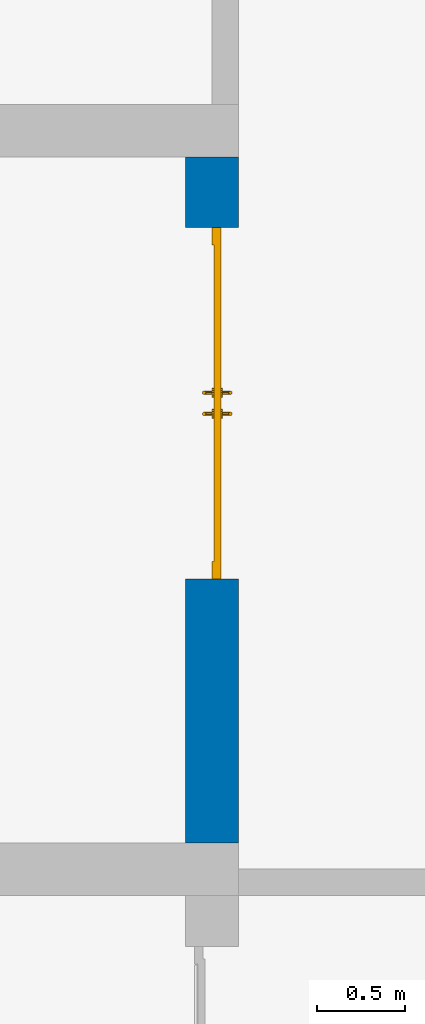
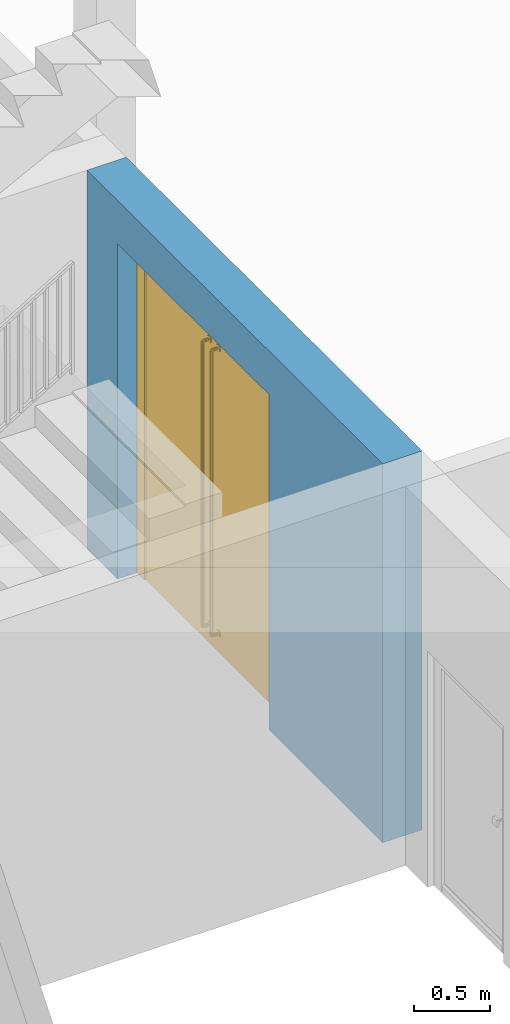
# One storey, part 18 of 23: 1 door, 1 wall, 1 opening.
"""IFC4 building model written with IfcOpenShell, lengths in metres."""

from ifc_helpers import new_model, entity, si_unit, converted_unit, derived_unit, direction, frame, origin_with_axes, place, context, subcontext, project, spatial, polygons, material, type_object, element, fill, save


model = new_model("IFC4")

# Units and contexts
model_context = context("Model", 3, precision=1e-05, world=origin_with_axes(), true_north=direction((0.0, 1.0)))
body_context = subcontext(model_context, "Body", "Model", "MODEL_VIEW")
ifc_project = project(units=[si_unit("LENGTHUNIT", "METRE"), si_unit("AREAUNIT", "SQUARE_METRE"), si_unit("VOLUMEUNIT", "CUBIC_METRE"), converted_unit("PLANEANGLEUNIT", "DEGREE", entity("IfcPlaneAngleMeasure", 0.0174532925199), si_unit("PLANEANGLEUNIT", "RADIAN"), dimensions=[0, 0, 0, 0, 0, 0, 0]), converted_unit("TIMEUNIT", "Year", entity("IfcTimeMeasure", 31556926.0), si_unit("TIMEUNIT", "SECOND"), dimensions=[0, 0, 1, 0, 0, 0, 0]), si_unit("MASSUNIT", "GRAM", prefix="KILO"), si_unit("THERMODYNAMICTEMPERATUREUNIT", "DEGREE_CELSIUS"), si_unit("LUMINOUSINTENSITYUNIT", "LUMEN"), si_unit("ENERGYUNIT", "JOULE", prefix="MEGA"), derived_unit("THERMALCONDUCTANCEUNIT", [(si_unit("POWERUNIT", "WATT"), 1), (si_unit("LENGTHUNIT", "METRE"), -1), (si_unit("THERMODYNAMICTEMPERATUREUNIT", "KELVIN"), -1)]), derived_unit("SPECIFICHEATCAPACITYUNIT", [(si_unit("ENERGYUNIT", "JOULE"), 1), (si_unit("MASSUNIT", "GRAM", prefix="KILO"), -1), (si_unit("THERMODYNAMICTEMPERATUREUNIT", "KELVIN"), -1)]), derived_unit("MASSDENSITYUNIT", [(si_unit("MASSUNIT", "GRAM", prefix="KILO"), 1), (si_unit("VOLUMEUNIT", "CUBIC_METRE"), -1)])], contexts=[model_context])

# Site, building, storey
site_placement = place(None, origin_with_axes())
site = spatial("IfcSite", under=ifc_project, at=site_placement, CompositionType="ELEMENT")
building_placement = place(site_placement, origin_with_axes())
building = spatial("IfcBuilding", under=site, at=building_placement, CompositionType="ELEMENT")
storey_placement = place(building_placement, origin_with_axes())
storey = spatial("IfcBuildingStorey", under=building, at=storey_placement, Name="0. Geschoss", CompositionType="ELEMENT", Elevation=0.0)

# Wall, opening, door
ifc_material = material()
wall_type = type_object("IfcWallType", Name="300", PredefinedType="NOTDEFINED")
wall_placement = place(storey_placement, frame((2.8378006196, -2.52881223104, 0.0), z_axis=(0.0, 0.0, 1.0), x_axis=(0.0, 1.0, 0.0)))
wall = element("IfcWall", 1, at=wall_placement, inside=storey, type_object=wall_type, material=ifc_material, Name="Wand-001", PredefinedType="NOTDEFINED", context=body_context, shape_type="Tessellation", body=[
    polygons([(1.5, 0.0, 2.7), (1.5, 0.3, 2.7), (3.5, 0.3, 2.7), (3.5, 0.0, 2.7), (1.5, 0.1, 0.0), (1.5, 0.3, 0.0), (1.5, 0.0, 0.0), (0.0, 0.3, 0.0), (0.0, 0.3, 3.05), (3.9, 0.3, 3.05), (3.9, 0.3, 0.0), (3.5, 0.3, 0.0), (3.5, 0.1, 0.0), (3.5, 0.0, 0.0), (3.9, 0.0, 3.05), (0.0, 0.0, 3.05), (0.0, 0.0, 0.0), (3.9, 0.0, 0.0)], [[[1, 2, 3, 4]], [[5, 6, 2, 1, 7]], [[2, 6, 8, 9, 10, 11, 12, 3]], [[4, 3, 12, 13, 14]], [[15, 16, 17, 7, 1, 4, 14, 18]], [[6, 5, 7, 17, 8]], [[9, 8, 17, 16]], [[15, 10, 9, 16]], [[15, 18, 11, 10]], [[13, 12, 11, 18, 14]]], closed=True),
])
opening_placement = place(wall_placement, frame((2.5, 0.0, 0.0), z_axis=(0.0, 0.0, 1.0), x_axis=(1.0, 0.0, 0.0)))
opening = element("IfcOpeningElement", 2, at=opening_placement, cuts=wall, context=body_context, identifier="Reference", shape_type="Tessellation", body=[
    polygons([(1.0, 0.1, 0.0), (1.0, 0.1, 2.7), (1.0, -0.001, 2.7), (1.0, -0.001, 0.0), (1.0, 0.301, 0.0), (1.0, 0.301, 2.7), (-1.0, 0.1, 2.7), (-1.0, -0.001, 2.7), (-1.0, 0.301, 2.7), (-1.0, -0.001, 0.0), (-1.0, 0.1, 0.0), (-1.0, 0.301, 0.0)], [[[1, 2, 3, 4]], [[2, 1, 5, 6]], [[7, 8, 3, 2, 6, 9]], [[8, 10, 4, 3]], [[1, 4, 10, 11, 12, 5]], [[6, 5, 12, 9]], [[7, 11, 10, 8]], [[11, 7, 9, 12]]], closed=True),
])
door_type = type_object("IfcDoorType", Name="Eingang 02 2-Fl 26", OperationType="DOUBLE_DOOR_SINGLE_SWING", PredefinedType="DOOR")
door_placement = place(opening_placement, frame((0.9, 0.0, 0.0), z_axis=(0.0, 0.0, 1.0), x_axis=(-1.0, 0.0, 0.0)))
door = element("IfcDoor", 3, at=door_placement, inside=storey, type_object=door_type, OverallHeight=2.7, OverallWidth=2.0, PredefinedType="DOOR", context=body_context, shape_type="Tessellation", body=[
    polygons([(-0.1, -0.15, 0.0), (-0.1, -0.15, 2.7), (-0.1, -0.14, 2.7), (-0.1, -0.14, 0.0), (0.0, -0.15, 0.0), (0.0, -0.15, 2.6), (0.7999, -0.15, 2.6), (0.8999, -0.15, 2.6), (1.8, -0.15, 2.6), (1.8, -0.15, 0.0), (1.9, -0.15, 0.0), (1.9, -0.15, 2.7), (1.9, -0.14, 2.7), (1.9, -0.14, 0.0), (1.8, -0.14, 0.0), (1.8, -0.14, 2.6), (0.8999, -0.14, 2.6), (0.7999, -0.14, 2.6), (0.0, -0.14, 2.6), (0.0, -0.14, 0.0)], [[[1, 2, 3, 4]], [[1, 5, 6, 7, 8, 9, 10, 11, 12, 2]], [[2, 12, 13, 3]], [[4, 3, 13, 14, 15, 16, 17, 18, 19, 20]], [[5, 1, 4, 20]], [[6, 5, 20, 19]], [[7, 6, 19, 18]], [[8, 7, 18, 17]], [[9, 8, 17, 16]], [[10, 9, 16, 15]], [[11, 10, 15, 14]], [[12, 11, 14, 13]]], closed=True),
    polygons([(-0.1, -0.14, 0.0), (-0.1, -0.14, 2.7), (-0.1, -0.1, 2.7), (-0.1, -0.1, 0.0), (0.0, -0.14, 0.0), (0.0, -0.14, 2.6), (0.7999, -0.14, 2.6), (0.8999, -0.14, 2.6), (1.8, -0.14, 2.6), (1.8, -0.14, 0.0), (1.9, -0.14, 0.0), (1.9, -0.14, 2.7), (1.9, -0.1, 2.7), (1.9, -0.1, 0.0), (1.8, -0.1, 0.0), (1.8, -0.1, 2.6), (0.8999, -0.1, 2.6), (0.7999, -0.1, 2.6), (0.0, -0.1, 2.6), (0.0, -0.1, 0.0)], [[[1, 2, 3, 4]], [[1, 5, 6, 7, 8, 9, 10, 11, 12, 2]], [[2, 12, 13, 3]], [[4, 3, 13, 14, 15, 16, 17, 18, 19, 20]], [[5, 1, 4, 20]], [[6, 5, 20, 19]], [[7, 6, 19, 18]], [[8, 7, 18, 17]], [[9, 8, 17, 16]], [[10, 9, 16, 15]], [[11, 10, 15, 14]], [[12, 11, 14, 13]]], closed=True),
    polygons([(0.0, -0.14, 0.0), (0.0, -0.1, 0.0), (0.9, -0.1, 0.0), (0.9, -0.14, 0.0), (0.0, -0.14, 2.6), (0.0, -0.1, 2.6), (0.9, -0.1, 2.6), (0.9, -0.14, 2.6)], [[[1, 2, 3, 4]], [[5, 6, 2, 1]], [[2, 6, 7, 3]], [[4, 3, 7, 8]], [[1, 4, 8, 5]], [[8, 7, 6, 5]]], closed=True),
    polygons([(0.84, -0.15, 0.14), (0.84, -0.181316524976, 0.14), (0.832928932188, -0.180930923738, 0.142928932188), (0.832928932188, -0.15, 0.142928932188), (0.847071067812, -0.15, 0.142928932188), (0.847071067812, -0.180930923738, 0.142928932188), (0.84, -0.192676380902, 0.143043864222), (0.832928932188, -0.191160254038, 0.145669872981), (0.83, -0.18, 0.15), (0.83, -0.15, 0.15), (0.832928932188, -0.15, 0.157071067812), (0.84, -0.15, 0.16), (0.847071067812, -0.15, 0.157071067812), (0.85, -0.15, 0.15), (0.85, -0.18, 0.15), (0.847071067812, -0.191160254038, 0.145669872981), (0.84, -0.201956135778, 0.152323619098), (0.832928932188, -0.199330127019, 0.153839745962), (0.83, -0.1875, 0.152009618943), (0.832928932188, -0.179069076262, 0.157071067812), (0.84, -0.178683475024, 0.16), (0.847071067812, -0.179069076262, 0.157071067812), (0.85, -0.1875, 0.152009618943), (0.847071067812, -0.199330127019, 0.153839745962), (0.84, -0.205, 0.163683475024), (0.832928932188, -0.202071067812, 0.164069076262), (0.83, -0.192990381057, 0.1575), (0.832928932188, -0.183839745962, 0.158349364905), (0.84, -0.182323619098, 0.160975373665), (0.847071067812, -0.183839745962, 0.158349364905), (0.85, -0.192990381057, 0.1575), (0.847071067812, -0.202071067812, 0.164069076262), (0.84, -0.205, 2.43631652498), (0.832928932188, -0.202071067812, 2.43593092374), (0.83, -0.195, 0.165), (0.832928932188, -0.186650635095, 0.161160254038), (0.84, -0.184024626335, 0.162676380902), (0.847071067812, -0.186650635095, 0.161160254038), (0.85, -0.195, 0.165), (0.847071067812, -0.202071067812, 2.43593092374), (0.84, -0.201956135778, 2.4476763809), (0.832928932188, -0.199330127019, 2.44616025404), (0.83, -0.195, 2.435), (0.832928932188, -0.187928932188, 0.165930923738), (0.84, -0.185, 0.166316524976), (0.847071067812, -0.187928932188, 0.165930923738), (0.85, -0.195, 2.435), (0.847071067812, -0.199330127019, 2.44616025404), (0.84, -0.192676380902, 2.45695613578), (0.832928932188, -0.191160254038, 2.45433012702), (0.83, -0.192990381057, 2.4425), (0.832928932188, -0.187928932188, 2.43406907626), (0.84, -0.185, 2.43368347502), (0.847071067812, -0.187928932188, 2.43406907626), (0.85, -0.192990381057, 2.4425), (0.847071067812, -0.191160254038, 2.45433012702), (0.84, -0.181316524976, 2.46), (0.832928932188, -0.180930923738, 2.45707106781), (0.83, -0.1875, 2.44799038106), (0.832928932188, -0.186650635095, 2.43883974596), (0.84, -0.184024626335, 2.4373236191), (0.847071067812, -0.186650635095, 2.43883974596), (0.85, -0.1875, 2.44799038106), (0.847071067812, -0.180930923738, 2.45707106781), (0.84, -0.15, 2.46), (0.832928932188, -0.15, 2.45707106781), (0.83, -0.18, 2.45), (0.832928932188, -0.183839745962, 2.44165063509), (0.84, -0.182323619098, 2.43902462634), (0.847071067812, -0.183839745962, 2.44165063509), (0.85, -0.18, 2.45), (0.847071067812, -0.15, 2.45707106781), (0.85, -0.15, 2.45), (0.847071067812, -0.15, 2.44292893219), (0.84, -0.15, 2.44), (0.832928932188, -0.15, 2.44292893219), (0.83, -0.15, 2.45), (0.832928932188, -0.179069076262, 2.44292893219), (0.84, -0.178683475024, 2.44), (0.847071067812, -0.179069076262, 2.44292893219)], [[[1, 2, 3, 4]], [[5, 6, 2, 1]], [[2, 7, 8, 3]], [[4, 3, 9, 10]], [[1, 4, 10, 11, 12, 13, 14, 5]], [[14, 15, 6, 5]], [[6, 16, 7, 2]], [[7, 17, 18, 8]], [[3, 8, 19, 9]], [[10, 9, 20, 11]], [[11, 20, 21, 12]], [[12, 21, 22, 13]], [[13, 22, 15, 14]], [[15, 23, 16, 6]], [[16, 24, 17, 7]], [[17, 25, 26, 18]], [[8, 18, 27, 19]], [[9, 19, 28, 20]], [[20, 28, 29, 21]], [[21, 29, 30, 22]], [[22, 30, 23, 15]], [[23, 31, 24, 16]], [[24, 32, 25, 17]], [[25, 33, 34, 26]], [[18, 26, 35, 27]], [[19, 27, 36, 28]], [[28, 36, 37, 29]], [[29, 37, 38, 30]], [[30, 38, 31, 23]], [[31, 39, 32, 24]], [[32, 40, 33, 25]], [[33, 41, 42, 34]], [[26, 34, 43, 35]], [[27, 35, 44, 36]], [[36, 44, 45, 37]], [[37, 45, 46, 38]], [[38, 46, 39, 31]], [[39, 47, 40, 32]], [[40, 48, 41, 33]], [[41, 49, 50, 42]], [[34, 42, 51, 43]], [[35, 43, 52, 44]], [[44, 52, 53, 45]], [[45, 53, 54, 46]], [[46, 54, 47, 39]], [[47, 55, 48, 40]], [[48, 56, 49, 41]], [[49, 57, 58, 50]], [[42, 50, 59, 51]], [[43, 51, 60, 52]], [[52, 60, 61, 53]], [[53, 61, 62, 54]], [[54, 62, 55, 47]], [[55, 63, 56, 48]], [[56, 64, 57, 49]], [[57, 65, 66, 58]], [[50, 58, 67, 59]], [[51, 59, 68, 60]], [[60, 68, 69, 61]], [[61, 69, 70, 62]], [[62, 70, 63, 55]], [[63, 71, 64, 56]], [[64, 72, 65, 57]], [[65, 72, 73, 74, 75, 76, 77, 66]], [[58, 66, 77, 67]], [[59, 67, 78, 68]], [[68, 78, 79, 69]], [[69, 79, 80, 70]], [[70, 80, 71, 63]], [[71, 73, 72, 64]], [[80, 74, 73, 71]], [[79, 75, 74, 80]], [[78, 76, 75, 79]], [[67, 77, 76, 78]]], closed=True),
    polygons([(0.863382685902, -0.149, 0.1365), (0.863382685902, -0.14, 0.1365), (0.867, -0.14, 0.15), (0.867, -0.149, 0.15), (0.8535, -0.149, 0.126617314098), (0.8535, -0.14, 0.126617314098), (0.863382685902, -0.14, 0.1635), (0.863382685902, -0.149, 0.1635), (0.8535, -0.149, 0.173382685902), (0.84, -0.149, 0.177), (0.8265, -0.149, 0.173382685902), (0.816617314098, -0.149, 0.1635), (0.813, -0.149, 0.15), (0.816617314098, -0.149, 0.1365), (0.8265, -0.149, 0.126617314098), (0.84, -0.149, 0.123), (0.84, -0.14, 0.123), (0.8535, -0.14, 0.173382685902), (0.84, -0.14, 0.177), (0.8265, -0.14, 0.173382685902), (0.816617314098, -0.14, 0.1635), (0.813, -0.14, 0.15), (0.816617314098, -0.14, 0.1365), (0.8265, -0.14, 0.126617314098)], [[[1, 2, 3, 4]], [[5, 6, 2, 1]], [[4, 3, 7, 8]], [[4, 8, 9, 10, 11, 12, 13, 14, 15, 16, 5, 1]], [[16, 17, 6, 5]], [[8, 7, 18, 9]], [[9, 18, 19, 10]], [[10, 19, 20, 11]], [[11, 20, 21, 12]], [[12, 21, 22, 13]], [[13, 22, 23, 14]], [[14, 23, 24, 15]], [[15, 24, 17, 16]]], closed=False),
    polygons([(0.863382685902, -0.149, 2.4365), (0.863382685902, -0.14, 2.4365), (0.867, -0.14, 2.45), (0.867, -0.149, 2.45), (0.8535, -0.149, 2.4266173141), (0.8535, -0.14, 2.4266173141), (0.863382685902, -0.14, 2.4635), (0.863382685902, -0.149, 2.4635), (0.8535, -0.149, 2.4733826859), (0.84, -0.149, 2.477), (0.8265, -0.149, 2.4733826859), (0.816617314098, -0.149, 2.4635), (0.813, -0.149, 2.45), (0.816617314098, -0.149, 2.4365), (0.8265, -0.149, 2.4266173141), (0.84, -0.149, 2.423), (0.84, -0.14, 2.423), (0.8535, -0.14, 2.4733826859), (0.84, -0.14, 2.477), (0.8265, -0.14, 2.4733826859), (0.816617314098, -0.14, 2.4635), (0.813, -0.14, 2.45), (0.816617314098, -0.14, 2.4365), (0.8265, -0.14, 2.4266173141)], [[[1, 2, 3, 4]], [[5, 6, 2, 1]], [[4, 3, 7, 8]], [[4, 8, 9, 10, 11, 12, 13, 14, 15, 16, 5, 1]], [[16, 17, 6, 5]], [[8, 7, 18, 9]], [[9, 18, 19, 10]], [[10, 19, 20, 11]], [[11, 20, 21, 12]], [[12, 21, 22, 13]], [[13, 22, 23, 14]], [[14, 23, 24, 15]], [[15, 24, 17, 16]]], closed=False),
    polygons([(0.84, -0.09, 0.14), (0.832928932188, -0.09, 0.142928932188), (0.832928932188, -0.059069076262, 0.142928932188), (0.84, -0.0586834750241, 0.14), (0.847071067812, -0.09, 0.142928932188), (0.85, -0.09, 0.15), (0.847071067812, -0.09, 0.157071067812), (0.84, -0.09, 0.16), (0.832928932188, -0.09, 0.157071067812), (0.83, -0.09, 0.15), (0.83, -0.06, 0.15), (0.832928932188, -0.0488397459622, 0.145669872981), (0.84, -0.0473236190979, 0.143043864222), (0.847071067812, -0.059069076262, 0.142928932188), (0.85, -0.06, 0.15), (0.847071067812, -0.060930923738, 0.157071067812), (0.84, -0.0613165249759, 0.16), (0.832928932188, -0.060930923738, 0.157071067812), (0.83, -0.0525, 0.152009618943), (0.832928932188, -0.0406698729811, 0.153839745962), (0.84, -0.0380438642216, 0.152323619098), (0.847071067812, -0.0488397459622, 0.145669872981), (0.85, -0.0525, 0.152009618943), (0.847071067812, -0.0561602540378, 0.158349364905), (0.84, -0.0576763809021, 0.160975373665), (0.832928932188, -0.0561602540378, 0.158349364905), (0.83, -0.0470096189432, 0.1575), (0.832928932188, -0.0379289321881, 0.164069076262), (0.84, -0.035, 0.163683475024), (0.847071067812, -0.0406698729811, 0.153839745962), (0.85, -0.0470096189432, 0.1575), (0.847071067812, -0.0533493649054, 0.161160254038), (0.84, -0.0559753736649, 0.162676380902), (0.832928932188, -0.0533493649054, 0.161160254038), (0.83, -0.045, 0.165), (0.832928932188, -0.0379289321881, 2.43593092374), (0.84, -0.035, 2.43631652498), (0.847071067812, -0.0379289321881, 0.164069076262), (0.85, -0.045, 0.165), (0.847071067812, -0.0520710678119, 0.165930923738), (0.84, -0.055, 0.166316524976), (0.832928932188, -0.0520710678119, 0.165930923738), (0.83, -0.045, 2.435), (0.832928932188, -0.0406698729811, 2.44616025404), (0.84, -0.0380438642216, 2.4476763809), (0.847071067812, -0.0379289321881, 2.43593092374), (0.85, -0.045, 2.435), (0.847071067812, -0.0520710678119, 2.43406907626), (0.84, -0.055, 2.43368347502), (0.832928932188, -0.0520710678119, 2.43406907626), (0.83, -0.0470096189432, 2.4425), (0.832928932188, -0.0488397459622, 2.45433012702), (0.84, -0.0473236190979, 2.45695613578), (0.847071067812, -0.0406698729811, 2.44616025404), (0.85, -0.0470096189432, 2.4425), (0.847071067812, -0.0533493649054, 2.43883974596), (0.84, -0.0559753736649, 2.4373236191), (0.832928932188, -0.0533493649054, 2.43883974596), (0.83, -0.0525, 2.44799038106), (0.832928932188, -0.059069076262, 2.45707106781), (0.84, -0.0586834750241, 2.46), (0.847071067812, -0.0488397459622, 2.45433012702), (0.85, -0.0525, 2.44799038106), (0.847071067812, -0.0561602540378, 2.44165063509), (0.84, -0.0576763809021, 2.43902462634), (0.832928932188, -0.0561602540378, 2.44165063509), (0.83, -0.06, 2.45), (0.832928932188, -0.09, 2.45707106781), (0.84, -0.09, 2.46), (0.847071067812, -0.059069076262, 2.45707106781), (0.85, -0.06, 2.45), (0.847071067812, -0.060930923738, 2.44292893219), (0.84, -0.0613165249759, 2.44), (0.832928932188, -0.060930923738, 2.44292893219), (0.83, -0.09, 2.45), (0.832928932188, -0.09, 2.44292893219), (0.84, -0.09, 2.44), (0.847071067812, -0.09, 2.44292893219), (0.85, -0.09, 2.45), (0.847071067812, -0.09, 2.45707106781)], [[[1, 2, 3, 4]], [[1, 5, 6, 7, 8, 9, 10, 2]], [[2, 10, 11, 3]], [[4, 3, 12, 13]], [[5, 1, 4, 14]], [[6, 5, 14, 15]], [[7, 6, 15, 16]], [[8, 7, 16, 17]], [[9, 8, 17, 18]], [[10, 9, 18, 11]], [[3, 11, 19, 12]], [[13, 12, 20, 21]], [[14, 4, 13, 22]], [[15, 14, 22, 23]], [[16, 15, 23, 24]], [[17, 16, 24, 25]], [[18, 17, 25, 26]], [[11, 18, 26, 19]], [[12, 19, 27, 20]], [[21, 20, 28, 29]], [[22, 13, 21, 30]], [[23, 22, 30, 31]], [[24, 23, 31, 32]], [[25, 24, 32, 33]], [[26, 25, 33, 34]], [[19, 26, 34, 27]], [[20, 27, 35, 28]], [[29, 28, 36, 37]], [[30, 21, 29, 38]], [[31, 30, 38, 39]], [[32, 31, 39, 40]], [[33, 32, 40, 41]], [[34, 33, 41, 42]], [[27, 34, 42, 35]], [[28, 35, 43, 36]], [[37, 36, 44, 45]], [[38, 29, 37, 46]], [[39, 38, 46, 47]], [[40, 39, 47, 48]], [[41, 40, 48, 49]], [[42, 41, 49, 50]], [[35, 42, 50, 43]], [[36, 43, 51, 44]], [[45, 44, 52, 53]], [[46, 37, 45, 54]], [[47, 46, 54, 55]], [[48, 47, 55, 56]], [[49, 48, 56, 57]], [[50, 49, 57, 58]], [[43, 50, 58, 51]], [[44, 51, 59, 52]], [[53, 52, 60, 61]], [[54, 45, 53, 62]], [[55, 54, 62, 63]], [[56, 55, 63, 64]], [[57, 56, 64, 65]], [[58, 57, 65, 66]], [[51, 58, 66, 59]], [[52, 59, 67, 60]], [[61, 60, 68, 69]], [[62, 53, 61, 70]], [[63, 62, 70, 71]], [[64, 63, 71, 72]], [[65, 64, 72, 73]], [[66, 65, 73, 74]], [[59, 66, 74, 67]], [[60, 67, 75, 68]], [[69, 68, 75, 76, 77, 78, 79, 80]], [[70, 61, 69, 80]], [[71, 70, 80, 79]], [[72, 71, 79, 78]], [[73, 72, 78, 77]], [[74, 73, 77, 76]], [[67, 74, 76, 75]]], closed=True),
    polygons([(0.863382685902, -0.091, 0.1365), (0.867, -0.091, 0.15), (0.867, -0.1, 0.15), (0.863382685902, -0.1, 0.1365), (0.8535, -0.091, 0.126617314098), (0.84, -0.091, 0.123), (0.8265, -0.091, 0.126617314098), (0.816617314098, -0.091, 0.1365), (0.813, -0.091, 0.15), (0.816617314098, -0.091, 0.1635), (0.8265, -0.091, 0.173382685902), (0.84, -0.091, 0.177), (0.8535, -0.091, 0.173382685902), (0.863382685902, -0.091, 0.1635), (0.863382685902, -0.1, 0.1635), (0.8535, -0.1, 0.126617314098), (0.84, -0.1, 0.123), (0.8265, -0.1, 0.126617314098), (0.816617314098, -0.1, 0.1365), (0.813, -0.1, 0.15), (0.816617314098, -0.1, 0.1635), (0.8265, -0.1, 0.173382685902), (0.84, -0.1, 0.177), (0.8535, -0.1, 0.173382685902)], [[[1, 2, 3, 4]], [[2, 1, 5, 6, 7, 8, 9, 10, 11, 12, 13, 14]], [[2, 14, 15, 3]], [[5, 1, 4, 16]], [[6, 5, 16, 17]], [[7, 6, 17, 18]], [[8, 7, 18, 19]], [[9, 8, 19, 20]], [[10, 9, 20, 21]], [[11, 10, 21, 22]], [[12, 11, 22, 23]], [[13, 12, 23, 24]], [[14, 13, 24, 15]]], closed=False),
    polygons([(0.863382685902, -0.091, 2.4365), (0.867, -0.091, 2.45), (0.867, -0.1, 2.45), (0.863382685902, -0.1, 2.4365), (0.8535, -0.091, 2.4266173141), (0.84, -0.091, 2.423), (0.8265, -0.091, 2.4266173141), (0.816617314098, -0.091, 2.4365), (0.813, -0.091, 2.45), (0.816617314098, -0.091, 2.4635), (0.8265, -0.091, 2.4733826859), (0.84, -0.091, 2.477), (0.8535, -0.091, 2.4733826859), (0.863382685902, -0.091, 2.4635), (0.863382685902, -0.1, 2.4635), (0.8535, -0.1, 2.4266173141), (0.84, -0.1, 2.423), (0.8265, -0.1, 2.4266173141), (0.816617314098, -0.1, 2.4365), (0.813, -0.1, 2.45), (0.816617314098, -0.1, 2.4635), (0.8265, -0.1, 2.4733826859), (0.84, -0.1, 2.477), (0.8535, -0.1, 2.4733826859)], [[[1, 2, 3, 4]], [[2, 1, 5, 6, 7, 8, 9, 10, 11, 12, 13, 14]], [[2, 14, 15, 3]], [[5, 1, 4, 16]], [[6, 5, 16, 17]], [[7, 6, 17, 18]], [[8, 7, 18, 19]], [[9, 8, 19, 20]], [[10, 9, 20, 21]], [[11, 10, 21, 22]], [[12, 11, 22, 23]], [[13, 12, 23, 24]], [[14, 13, 24, 15]]], closed=False),
    polygons([(1.8, -0.14, 0.0), (0.9, -0.14, 0.0), (0.9, -0.1, 0.0), (1.8, -0.1, 0.0), (1.8, -0.14, 2.6), (0.9, -0.14, 2.6), (0.9, -0.1, 2.6), (1.8, -0.1, 2.6)], [[[1, 2, 3, 4]], [[1, 5, 6, 2]], [[2, 6, 7, 3]], [[4, 3, 7, 8]], [[5, 1, 4, 8]], [[6, 5, 8, 7]]], closed=True),
    polygons([(0.96, -0.15, 0.14), (0.967071067812, -0.15, 0.142928932188), (0.967071067812, -0.180930923738, 0.142928932188), (0.96, -0.181316524976, 0.14), (0.952928932188, -0.15, 0.142928932188), (0.95, -0.15, 0.15), (0.952928932188, -0.15, 0.157071067812), (0.96, -0.15, 0.16), (0.967071067812, -0.15, 0.157071067812), (0.97, -0.15, 0.15), (0.97, -0.18, 0.15), (0.967071067812, -0.191160254038, 0.145669872981), (0.96, -0.192676380902, 0.143043864222), (0.952928932188, -0.180930923738, 0.142928932188), (0.95, -0.18, 0.15), (0.952928932188, -0.179069076262, 0.157071067812), (0.96, -0.178683475024, 0.16), (0.967071067812, -0.179069076262, 0.157071067812), (0.97, -0.1875, 0.152009618943), (0.967071067812, -0.199330127019, 0.153839745962), (0.96, -0.201956135778, 0.152323619098), (0.952928932188, -0.191160254038, 0.145669872981), (0.95, -0.1875, 0.152009618943), (0.952928932188, -0.183839745962, 0.158349364905), (0.96, -0.182323619098, 0.160975373665), (0.967071067812, -0.183839745962, 0.158349364905), (0.97, -0.192990381057, 0.1575), (0.967071067812, -0.202071067812, 0.164069076262), (0.96, -0.205, 0.163683475024), (0.952928932188, -0.199330127019, 0.153839745962), (0.95, -0.192990381057, 0.1575), (0.952928932188, -0.186650635095, 0.161160254038), (0.96, -0.184024626335, 0.162676380902), (0.967071067812, -0.186650635095, 0.161160254038), (0.97, -0.195, 0.165), (0.967071067812, -0.202071067812, 2.43593092374), (0.96, -0.205, 2.43631652498), (0.952928932188, -0.202071067812, 0.164069076262), (0.95, -0.195, 0.165), (0.952928932188, -0.187928932188, 0.165930923738), (0.96, -0.185, 0.166316524976), (0.967071067812, -0.187928932188, 0.165930923738), (0.97, -0.195, 2.435), (0.967071067812, -0.199330127019, 2.44616025404), (0.96, -0.201956135778, 2.4476763809), (0.952928932188, -0.202071067812, 2.43593092374), (0.95, -0.195, 2.435), (0.952928932188, -0.187928932188, 2.43406907626), (0.96, -0.185, 2.43368347502), (0.967071067812, -0.187928932188, 2.43406907626), (0.97, -0.192990381057, 2.4425), (0.967071067812, -0.191160254038, 2.45433012702), (0.96, -0.192676380902, 2.45695613578), (0.952928932188, -0.199330127019, 2.44616025404), (0.95, -0.192990381057, 2.4425), (0.952928932188, -0.186650635095, 2.43883974596), (0.96, -0.184024626335, 2.4373236191), (0.967071067812, -0.186650635095, 2.43883974596), (0.97, -0.1875, 2.44799038106), (0.967071067812, -0.180930923738, 2.45707106781), (0.96, -0.181316524976, 2.46), (0.952928932188, -0.191160254038, 2.45433012702), (0.95, -0.1875, 2.44799038106), (0.952928932188, -0.183839745962, 2.44165063509), (0.96, -0.182323619098, 2.43902462634), (0.967071067812, -0.183839745962, 2.44165063509), (0.97, -0.18, 2.45), (0.967071067812, -0.15, 2.45707106781), (0.96, -0.15, 2.46), (0.952928932188, -0.180930923738, 2.45707106781), (0.95, -0.18, 2.45), (0.952928932188, -0.179069076262, 2.44292893219), (0.96, -0.178683475024, 2.44), (0.967071067812, -0.179069076262, 2.44292893219), (0.97, -0.15, 2.45), (0.967071067812, -0.15, 2.44292893219), (0.96, -0.15, 2.44), (0.952928932188, -0.15, 2.44292893219), (0.95, -0.15, 2.45), (0.952928932188, -0.15, 2.45707106781)], [[[1, 2, 3, 4]], [[1, 5, 6, 7, 8, 9, 10, 2]], [[2, 10, 11, 3]], [[4, 3, 12, 13]], [[5, 1, 4, 14]], [[6, 5, 14, 15]], [[7, 6, 15, 16]], [[8, 7, 16, 17]], [[9, 8, 17, 18]], [[10, 9, 18, 11]], [[3, 11, 19, 12]], [[13, 12, 20, 21]], [[14, 4, 13, 22]], [[15, 14, 22, 23]], [[16, 15, 23, 24]], [[17, 16, 24, 25]], [[18, 17, 25, 26]], [[11, 18, 26, 19]], [[12, 19, 27, 20]], [[21, 20, 28, 29]], [[22, 13, 21, 30]], [[23, 22, 30, 31]], [[24, 23, 31, 32]], [[25, 24, 32, 33]], [[26, 25, 33, 34]], [[19, 26, 34, 27]], [[20, 27, 35, 28]], [[29, 28, 36, 37]], [[30, 21, 29, 38]], [[31, 30, 38, 39]], [[32, 31, 39, 40]], [[33, 32, 40, 41]], [[34, 33, 41, 42]], [[27, 34, 42, 35]], [[28, 35, 43, 36]], [[37, 36, 44, 45]], [[38, 29, 37, 46]], [[39, 38, 46, 47]], [[40, 39, 47, 48]], [[41, 40, 48, 49]], [[42, 41, 49, 50]], [[35, 42, 50, 43]], [[36, 43, 51, 44]], [[45, 44, 52, 53]], [[46, 37, 45, 54]], [[47, 46, 54, 55]], [[48, 47, 55, 56]], [[49, 48, 56, 57]], [[50, 49, 57, 58]], [[43, 50, 58, 51]], [[44, 51, 59, 52]], [[53, 52, 60, 61]], [[54, 45, 53, 62]], [[55, 54, 62, 63]], [[56, 55, 63, 64]], [[57, 56, 64, 65]], [[58, 57, 65, 66]], [[51, 58, 66, 59]], [[52, 59, 67, 60]], [[61, 60, 68, 69]], [[62, 53, 61, 70]], [[63, 62, 70, 71]], [[64, 63, 71, 72]], [[65, 64, 72, 73]], [[66, 65, 73, 74]], [[59, 66, 74, 67]], [[60, 67, 75, 68]], [[69, 68, 75, 76, 77, 78, 79, 80]], [[70, 61, 69, 80]], [[71, 70, 80, 79]], [[72, 71, 79, 78]], [[73, 72, 78, 77]], [[74, 73, 77, 76]], [[67, 74, 76, 75]]], closed=True),
    polygons([(0.936617314098, -0.149, 0.1365), (0.933, -0.149, 0.15), (0.933, -0.14, 0.15), (0.936617314098, -0.14, 0.1365), (0.9465, -0.149, 0.126617314098), (0.96, -0.149, 0.123), (0.9735, -0.149, 0.126617314098), (0.983382685902, -0.149, 0.1365), (0.987, -0.149, 0.15), (0.983382685902, -0.149, 0.1635), (0.9735, -0.149, 0.173382685902), (0.96, -0.149, 0.177), (0.9465, -0.149, 0.173382685902), (0.936617314098, -0.149, 0.1635), (0.936617314098, -0.14, 0.1635), (0.9465, -0.14, 0.126617314098), (0.96, -0.14, 0.123), (0.9735, -0.14, 0.126617314098), (0.983382685902, -0.14, 0.1365), (0.987, -0.14, 0.15), (0.983382685902, -0.14, 0.1635), (0.9735, -0.14, 0.173382685902), (0.96, -0.14, 0.177), (0.9465, -0.14, 0.173382685902)], [[[1, 2, 3, 4]], [[2, 1, 5, 6, 7, 8, 9, 10, 11, 12, 13, 14]], [[2, 14, 15, 3]], [[5, 1, 4, 16]], [[6, 5, 16, 17]], [[7, 6, 17, 18]], [[8, 7, 18, 19]], [[9, 8, 19, 20]], [[10, 9, 20, 21]], [[11, 10, 21, 22]], [[12, 11, 22, 23]], [[13, 12, 23, 24]], [[14, 13, 24, 15]]], closed=False),
    polygons([(0.936617314098, -0.149, 2.4365), (0.933, -0.149, 2.45), (0.933, -0.14, 2.45), (0.936617314098, -0.14, 2.4365), (0.9465, -0.149, 2.4266173141), (0.96, -0.149, 2.423), (0.9735, -0.149, 2.4266173141), (0.983382685902, -0.149, 2.4365), (0.987, -0.149, 2.45), (0.983382685902, -0.149, 2.4635), (0.9735, -0.149, 2.4733826859), (0.96, -0.149, 2.477), (0.9465, -0.149, 2.4733826859), (0.936617314098, -0.149, 2.4635), (0.936617314098, -0.14, 2.4635), (0.9465, -0.14, 2.4266173141), (0.96, -0.14, 2.423), (0.9735, -0.14, 2.4266173141), (0.983382685902, -0.14, 2.4365), (0.987, -0.14, 2.45), (0.983382685902, -0.14, 2.4635), (0.9735, -0.14, 2.4733826859), (0.96, -0.14, 2.477), (0.9465, -0.14, 2.4733826859)], [[[1, 2, 3, 4]], [[2, 1, 5, 6, 7, 8, 9, 10, 11, 12, 13, 14]], [[2, 14, 15, 3]], [[5, 1, 4, 16]], [[6, 5, 16, 17]], [[7, 6, 17, 18]], [[8, 7, 18, 19]], [[9, 8, 19, 20]], [[10, 9, 20, 21]], [[11, 10, 21, 22]], [[12, 11, 22, 23]], [[13, 12, 23, 24]], [[14, 13, 24, 15]]], closed=False),
    polygons([(0.96, -0.09, 0.14), (0.96, -0.0586834750241, 0.14), (0.967071067812, -0.059069076262, 0.142928932188), (0.967071067812, -0.09, 0.142928932188), (0.952928932188, -0.09, 0.142928932188), (0.952928932188, -0.059069076262, 0.142928932188), (0.96, -0.047323619098, 0.143043864222), (0.967071067812, -0.0488397459622, 0.145669872981), (0.97, -0.06, 0.15), (0.97, -0.09, 0.15), (0.967071067812, -0.09, 0.157071067812), (0.96, -0.09, 0.16), (0.952928932188, -0.09, 0.157071067812), (0.95, -0.09, 0.15), (0.95, -0.06, 0.15), (0.952928932188, -0.0488397459622, 0.145669872981), (0.96, -0.0380438642216, 0.152323619098), (0.967071067812, -0.0406698729811, 0.153839745962), (0.97, -0.0525, 0.152009618943), (0.967071067812, -0.060930923738, 0.157071067812), (0.96, -0.0613165249759, 0.16), (0.952928932188, -0.060930923738, 0.157071067812), (0.95, -0.0525, 0.152009618943), (0.952928932188, -0.0406698729811, 0.153839745962), (0.96, -0.035, 0.163683475024), (0.967071067812, -0.0379289321881, 0.164069076262), (0.97, -0.0470096189432, 0.1575), (0.967071067812, -0.0561602540378, 0.158349364905), (0.96, -0.0576763809021, 0.160975373665), (0.952928932188, -0.0561602540378, 0.158349364905), (0.95, -0.0470096189432, 0.1575), (0.952928932188, -0.0379289321881, 0.164069076262), (0.96, -0.035, 2.43631652498), (0.967071067812, -0.0379289321881, 2.43593092374), (0.97, -0.045, 0.165), (0.967071067812, -0.0533493649054, 0.161160254038), (0.96, -0.0559753736649, 0.162676380902), (0.952928932188, -0.0533493649054, 0.161160254038), (0.95, -0.045, 0.165), (0.952928932188, -0.0379289321881, 2.43593092374), (0.96, -0.0380438642216, 2.4476763809), (0.967071067812, -0.0406698729811, 2.44616025404), (0.97, -0.045, 2.435), (0.967071067812, -0.0520710678119, 0.165930923738), (0.96, -0.055, 0.166316524976), (0.952928932188, -0.0520710678119, 0.165930923738), (0.95, -0.045, 2.435), (0.952928932188, -0.0406698729811, 2.44616025404), (0.96, -0.047323619098, 2.45695613578), (0.967071067812, -0.0488397459622, 2.45433012702), (0.97, -0.0470096189432, 2.4425), (0.967071067812, -0.0520710678119, 2.43406907626), (0.96, -0.055, 2.43368347502), (0.952928932188, -0.0520710678119, 2.43406907626), (0.95, -0.0470096189432, 2.4425), (0.952928932188, -0.0488397459622, 2.45433012702), (0.96, -0.0586834750241, 2.46), (0.967071067812, -0.059069076262, 2.45707106781), (0.97, -0.0525, 2.44799038106), (0.967071067812, -0.0533493649054, 2.43883974596), (0.96, -0.0559753736649, 2.4373236191), (0.952928932188, -0.0533493649054, 2.43883974596), (0.95, -0.0525, 2.44799038106), (0.952928932188, -0.059069076262, 2.45707106781), (0.96, -0.09, 2.46), (0.967071067812, -0.09, 2.45707106781), (0.97, -0.06, 2.45), (0.967071067812, -0.0561602540378, 2.44165063509), (0.96, -0.0576763809021, 2.43902462634), (0.952928932188, -0.0561602540378, 2.44165063509), (0.95, -0.06, 2.45), (0.952928932188, -0.09, 2.45707106781), (0.95, -0.09, 2.45), (0.952928932188, -0.09, 2.44292893219), (0.96, -0.09, 2.44), (0.967071067812, -0.09, 2.44292893219), (0.97, -0.09, 2.45), (0.967071067812, -0.060930923738, 2.44292893219), (0.96, -0.0613165249759, 2.44), (0.952928932188, -0.060930923738, 2.44292893219)], [[[1, 2, 3, 4]], [[5, 6, 2, 1]], [[2, 7, 8, 3]], [[4, 3, 9, 10]], [[1, 4, 10, 11, 12, 13, 14, 5]], [[14, 15, 6, 5]], [[6, 16, 7, 2]], [[7, 17, 18, 8]], [[3, 8, 19, 9]], [[10, 9, 20, 11]], [[11, 20, 21, 12]], [[12, 21, 22, 13]], [[13, 22, 15, 14]], [[15, 23, 16, 6]], [[16, 24, 17, 7]], [[17, 25, 26, 18]], [[8, 18, 27, 19]], [[9, 19, 28, 20]], [[20, 28, 29, 21]], [[21, 29, 30, 22]], [[22, 30, 23, 15]], [[23, 31, 24, 16]], [[24, 32, 25, 17]], [[25, 33, 34, 26]], [[18, 26, 35, 27]], [[19, 27, 36, 28]], [[28, 36, 37, 29]], [[29, 37, 38, 30]], [[30, 38, 31, 23]], [[31, 39, 32, 24]], [[32, 40, 33, 25]], [[33, 41, 42, 34]], [[26, 34, 43, 35]], [[27, 35, 44, 36]], [[36, 44, 45, 37]], [[37, 45, 46, 38]], [[38, 46, 39, 31]], [[39, 47, 40, 32]], [[40, 48, 41, 33]], [[41, 49, 50, 42]], [[34, 42, 51, 43]], [[35, 43, 52, 44]], [[44, 52, 53, 45]], [[45, 53, 54, 46]], [[46, 54, 47, 39]], [[47, 55, 48, 40]], [[48, 56, 49, 41]], [[49, 57, 58, 50]], [[42, 50, 59, 51]], [[43, 51, 60, 52]], [[52, 60, 61, 53]], [[53, 61, 62, 54]], [[54, 62, 55, 47]], [[55, 63, 56, 48]], [[56, 64, 57, 49]], [[57, 65, 66, 58]], [[50, 58, 67, 59]], [[51, 59, 68, 60]], [[60, 68, 69, 61]], [[61, 69, 70, 62]], [[62, 70, 63, 55]], [[63, 71, 64, 56]], [[64, 72, 65, 57]], [[65, 72, 73, 74, 75, 76, 77, 66]], [[58, 66, 77, 67]], [[59, 67, 78, 68]], [[68, 78, 79, 69]], [[69, 79, 80, 70]], [[70, 80, 71, 63]], [[71, 73, 72, 64]], [[80, 74, 73, 71]], [[79, 75, 74, 80]], [[78, 76, 75, 79]], [[67, 77, 76, 78]]], closed=True),
    polygons([(0.936617314098, -0.091, 0.1365), (0.936617314098, -0.1, 0.1365), (0.933, -0.1, 0.15), (0.933, -0.091, 0.15), (0.9465, -0.091, 0.126617314098), (0.9465, -0.1, 0.126617314098), (0.936617314098, -0.1, 0.1635), (0.936617314098, -0.091, 0.1635), (0.9465, -0.091, 0.173382685902), (0.96, -0.091, 0.177), (0.9735, -0.091, 0.173382685902), (0.983382685902, -0.091, 0.1635), (0.987, -0.091, 0.15), (0.983382685902, -0.091, 0.1365), (0.9735, -0.091, 0.126617314098), (0.96, -0.091, 0.123), (0.96, -0.1, 0.123), (0.9465, -0.1, 0.173382685902), (0.96, -0.1, 0.177), (0.9735, -0.1, 0.173382685902), (0.983382685902, -0.1, 0.1635), (0.987, -0.1, 0.15), (0.983382685902, -0.1, 0.1365), (0.9735, -0.1, 0.126617314098)], [[[1, 2, 3, 4]], [[5, 6, 2, 1]], [[4, 3, 7, 8]], [[4, 8, 9, 10, 11, 12, 13, 14, 15, 16, 5, 1]], [[16, 17, 6, 5]], [[8, 7, 18, 9]], [[9, 18, 19, 10]], [[10, 19, 20, 11]], [[11, 20, 21, 12]], [[12, 21, 22, 13]], [[13, 22, 23, 14]], [[14, 23, 24, 15]], [[15, 24, 17, 16]]], closed=False),
    polygons([(0.936617314098, -0.091, 2.4365), (0.936617314098, -0.1, 2.4365), (0.933, -0.1, 2.45), (0.933, -0.091, 2.45), (0.9465, -0.091, 2.4266173141), (0.9465, -0.1, 2.4266173141), (0.936617314098, -0.1, 2.4635), (0.936617314098, -0.091, 2.4635), (0.9465, -0.091, 2.4733826859), (0.96, -0.091, 2.477), (0.9735, -0.091, 2.4733826859), (0.983382685902, -0.091, 2.4635), (0.987, -0.091, 2.45), (0.983382685902, -0.091, 2.4365), (0.9735, -0.091, 2.4266173141), (0.96, -0.091, 2.423), (0.96, -0.1, 2.423), (0.9465, -0.1, 2.4733826859), (0.96, -0.1, 2.477), (0.9735, -0.1, 2.4733826859), (0.983382685902, -0.1, 2.4635), (0.987, -0.1, 2.45), (0.983382685902, -0.1, 2.4365), (0.9735, -0.1, 2.4266173141)], [[[1, 2, 3, 4]], [[5, 6, 2, 1]], [[4, 3, 7, 8]], [[4, 8, 9, 10, 11, 12, 13, 14, 15, 16, 5, 1]], [[16, 17, 6, 5]], [[8, 7, 18, 9]], [[9, 18, 19, 10]], [[10, 19, 20, 11]], [[11, 20, 21, 12]], [[12, 21, 22, 13]], [[13, 22, 23, 14]], [[14, 23, 24, 15]], [[15, 24, 17, 16]]], closed=False),
])
fill(opening, door)

save(model, "model.ifc")
